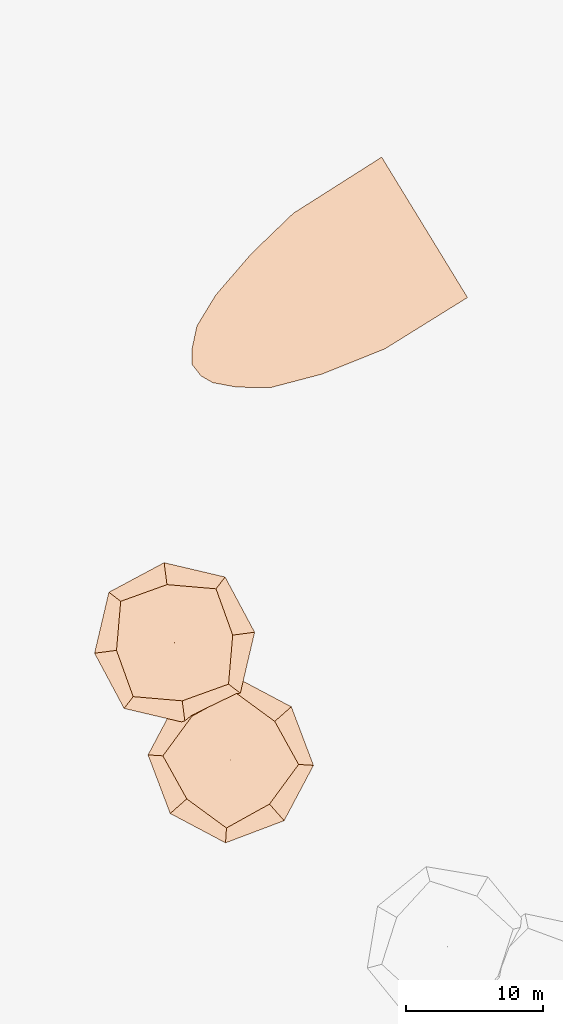
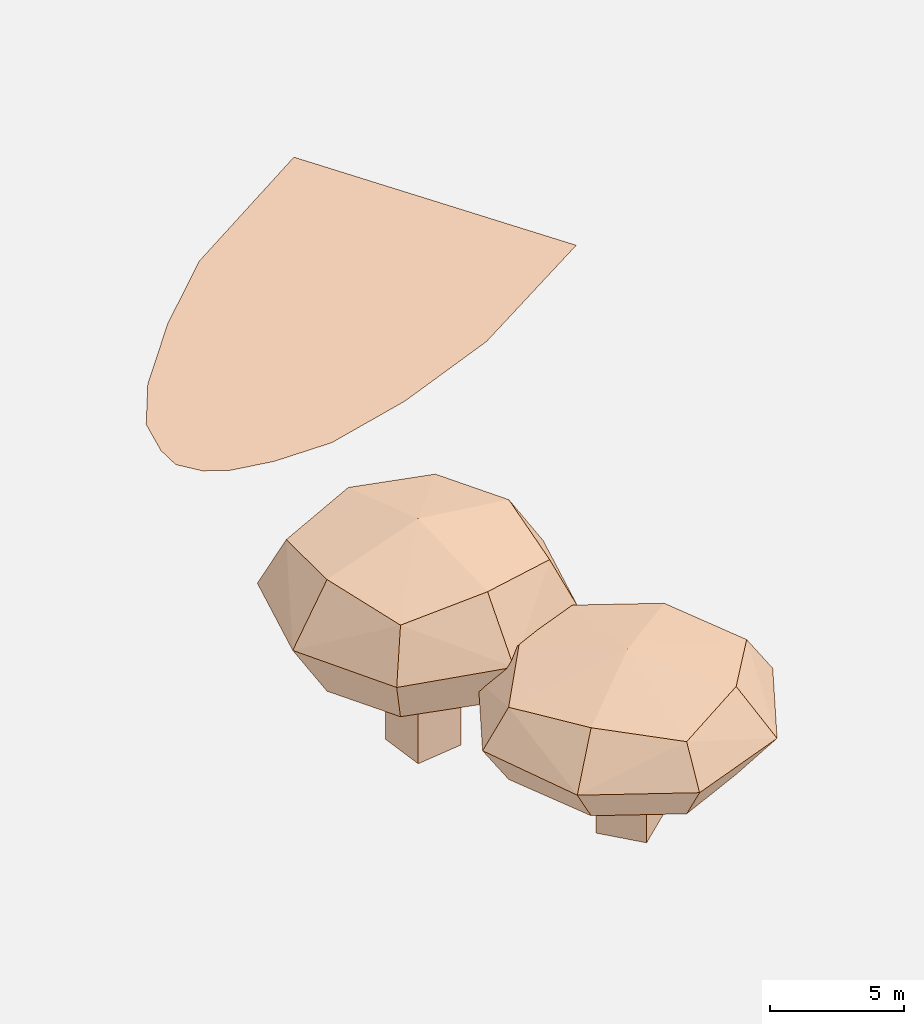
# Not in any storey, part 7 of 92: 3 geographic elements.
"""IFC4 model written with IfcOpenShell, lengths in metres."""

from ifc_helpers import new_model, si_unit, origin_with_axes, place, context, subcontext, project, spatial, triangles, material, element, save


model = new_model("IFC4")

# Units and contexts
model_context = context("Model", 3, precision=1e-05, world=origin_with_axes())
body_context = subcontext(model_context, "Body", "Model", "MODEL_VIEW")
ifc_project = project(units=[si_unit("VOLUMEUNIT", "CUBIC_METRE"), si_unit("LENGTHUNIT", "METRE"), si_unit("AREAUNIT", "SQUARE_METRE")], contexts=[model_context])

# Site
site_placement = place(None, origin_with_axes())
site = spatial("IfcSite", under=ifc_project, at=site_placement)

# Geographic elements
ifc_material_1 = material(Name="grass")
geographic_element_1_placement = place(site_placement, origin_with_axes())
element("IfcGeographicElement", 1, at=geographic_element_1_placement, inside=site, material=ifc_material_1, Name="cw_surface_grass", context=body_context, shape_type="Tessellation", body=[
    triangles([(428.3292698345774, -795.2040101195155, 0.0), (437.68484757364297, -795.2040101195155, 0.0), (435.03090837762966, -790.8601645183401, 0.0), (428.5964130531786, -794.9485099007724, 0.0), (421.5811732529401, -803.1426170163166, 0.0), (422.7426432110405, -807.277420437334, 0.0), (435.26319857055483, -804.815121837576, 0.0), (425.55337353890974, -797.8695821532289, 0.0), (421.2327379635523, -805.9533544667388, 0.0), (426.97036270922786, -807.6258592879982, 0.0), (435.03090837762966, -790.8543545206849, 0.0), (422.9517043846732, -800.8893819643757, 0.0), (421.2095089442598, -804.8848100825458, 0.0), (421.88315050374285, -806.7896062838224, 0.0), (424.5080676707464, -807.6026290816135, 0.0), (430.68704378297974, -806.6502309809752, 0.0), (441.27957154774055, -801.0752164929003, 0.0), (428.5964130531786, -794.942699012798, 0.0)], [[1, 2, 3], [3, 4, 1], [5, 6, 7], [7, 8, 5], [5, 9, 6], [6, 10, 7], [7, 11, 8], [8, 12, 5], [5, 13, 9], [9, 14, 6], [6, 15, 10], [10, 16, 7], [7, 17, 11], [11, 18, 8]], closed=False),
])
ifc_material_2 = material(Name="tree")
geographic_element_2_placement = place(site_placement, origin_with_axes())
element("IfcGeographicElement", 2, at=geographic_element_2_placement, inside=site, material=ifc_material_2, Name="cw_instances_tree_260", context=body_context, shape_type="Tessellation", body=[
    triangles([(421.0632924692762, -825.0554007047107, 5.950557368610615), (421.0632924692762, -825.0554007047107, 5.950557368610615), (421.0632924692762, -825.0554007047107, 5.950557368610615), (421.0632924692762, -825.0554007047107, 0.0), (421.0632924692762, -825.0554007047107, 0.0), (421.0632924692762, -825.0554007047107, 0.0), (421.3232781396344, -827.0384305711545, 5.950557368610615), (421.3232781396344, -827.0384305711545, 5.950557368610615), (421.3232781396344, -827.0384305711545, 5.950557368610615), (421.3232781396344, -827.0384305711545, 0.0), (421.3232781396344, -827.0384305711545, 0.0), (421.3232781396344, -827.0384305711545, 0.0), (419.0802626028323, -825.3153863750688, 5.950557368610615), (419.0802626028323, -825.3153863750688, 5.950557368610615), (419.0802626028323, -825.3153863750688, 5.950557368610615), (419.0802626028323, -825.3153863750688, 0.0), (419.0802626028323, -825.3153863750688, 0.0), (419.0802626028323, -825.3153863750688, 0.0), (419.3402482731905, -827.2984162415127, 5.950557368610615), (419.3402482731905, -827.2984162415127, 5.950557368610615), (419.3402482731905, -827.2984162415127, 5.950557368610615), (419.3402482731905, -827.2984162415127, 0.0), (419.3402482731905, -827.2984162415127, 0.0), (419.3402482731905, -827.2984162415127, 0.0), (422.97046032948157, -822.2839669872363, 8.863743321924314), (422.97046032948157, -822.2839669872363, 8.863743321924314), (422.97046032948157, -822.2839669872363, 8.863743321924314), (422.97046032948157, -822.2839669872363, 8.863743321924314), (422.97046032948157, -822.2839669872363, 8.863743321924314), (422.97046032948157, -822.2839669872363, 8.863743321924314), (422.9704605050486, -822.2839664801108, 4.698353330512501), (422.9704605050486, -822.2839664801108, 4.698353330512501), (422.9704605050486, -822.2839664801108, 4.698353330512501), (422.9704605050486, -822.2839664801108, 4.698353330512501), (422.9704605050486, -822.2839664801108, 4.698353330512501), (422.9704605050486, -822.2839664801108, 4.698353330512501), (423.88041019661085, -829.2245698327616, 8.863743321924314), (423.88041019661085, -829.2245698327616, 8.863743321924314), (423.88041019661085, -829.2245698327616, 8.863743321924314), (423.88041019661085, -829.2245698327616, 8.863743321924314), (423.88041019661085, -829.2245698327616, 8.863743321924314), (423.88041019661085, -829.2245698327616, 8.863743321924314), (423.88041019661085, -829.2245698327616, 4.698353330512501), (423.88041019661085, -829.2245698327616, 4.698353330512501), (423.88041019661085, -829.2245698327616, 4.698353330512501), (423.88041019661085, -829.2245698327616, 4.698353330512501), (423.88041019661085, -829.2245698327616, 4.698353330512501), (423.88041019661085, -829.2245698327616, 4.698353330512501), (416.02985643850707, -823.193916265268, 8.863743321924314), (416.02985643850707, -823.193916265268, 8.863743321924314), (416.02985643850707, -823.193916265268, 8.863743321924314), (416.02985643850707, -823.193916265268, 8.863743321924314), (416.02985643850707, -823.193916265268, 8.863743321924314), (416.02985643850707, -823.193916265268, 8.863743321924314), (416.0298569144343, -823.1939162028714, 4.698353330512501), (416.0298569144343, -823.1939162028714, 4.698353330512501), (416.0298569144343, -823.1939162028714, 4.698353330512501), (416.0298569144343, -823.1939162028714, 4.698353330512501), (416.0298569144343, -823.1939162028714, 4.698353330512501), (416.0298569144343, -823.1939162028714, 4.698353330512501), (416.9398061612676, -830.1345198558823, 8.863743321924314), (416.9398061612676, -830.1345198558823, 8.863743321924314), (416.9398061612676, -830.1345198558823, 8.863743321924314), (416.9398061612676, -830.1345198558823, 8.863743321924314), (416.9398061612676, -830.1345198558823, 8.863743321924314), (416.9398061612676, -830.1345198558823, 8.863743321924314), (416.9398061300693, -830.1345196179187, 4.698353330512501), (416.9398061300693, -830.1345196179187, 4.698353330512501), (416.9398061300693, -830.1345196179187, 4.698353330512501), (416.9398061300693, -830.1345196179187, 4.698353330512501), (416.9398061300693, -830.1345196179187, 4.698353330512501), (416.9398061300693, -830.1345196179187, 4.698353330512501), (415.72436421525055, -826.7639193198099, 4.241960964900109), (415.72436421525055, -826.7639193198099, 4.241960964900109), (415.72436421525055, -826.7639193198099, 4.241960964900109), (415.72436421525055, -826.7639193198099, 4.241960964900109), (419.40045729201717, -821.9784745096014, 4.241960964900109), (419.40045729201717, -821.9784745096014, 4.241960964900109), (419.40045729201717, -821.9784745096014, 4.241960964900109), (419.40045729201717, -821.9784745096014, 4.241960964900109), (423.63122591115956, -821.4237984383071, 6.781048683251871), (423.63122591115956, -821.4237984383071, 6.781048683251871), (423.63122591115956, -821.4237984383071, 6.781048683251871), (423.63122591115956, -821.4237984383071, 6.781048683251871), (416.2790402891446, -830.9946879587826, 6.781048683251871), (416.2790402891446, -830.9946879587826, 6.781048683251871), (416.2790402891446, -830.9946879587826, 6.781048683251871), (416.2790402891446, -830.9946879587826, 6.781048683251871), (424.74057858995616, -829.8853361509134, 6.781048683251871), (424.74057858995616, -829.8853361509134, 6.781048683251871), (424.74057858995616, -829.8853361509134, 6.781048683251871), (424.74057858995616, -829.8853361509134, 6.781048683251871), (415.1696886133838, -822.5331505886952, 6.781048683251871), (415.1696886133838, -822.5331505886952, 6.781048683251871), (415.1696886133838, -822.5331505886952, 6.781048683251871), (415.1696886133838, -822.5331505886952, 6.781048683251871), (420.5098095048017, -830.4400122833043, 9.320135330503241), (420.5098095048017, -830.4400122833043, 9.320135330503241), (420.5098095048017, -830.4400122833043, 9.320135330503241), (420.5098095048017, -830.4400122833043, 9.320135330503241), (424.18590244196616, -825.6545669467772, 9.320136728884307), (424.18590244196616, -825.6545669467772, 9.320136728884307), (424.18590244196616, -825.6545669467772, 9.320136728884307), (424.18590244196616, -825.6545669467772, 9.320136728884307), (420.5098093941293, -830.4400118237919, 4.241960964900109), (420.5098093941293, -830.4400118237919, 4.241960964900109), (420.5098093941293, -830.4400118237919, 4.241960964900109), (420.5098093941293, -830.4400118237919, 4.241960964900109), (415.7243642100508, -826.7639192801493, 9.320135330503241), (415.7243642100508, -826.7639192801493, 9.320135330503241), (415.7243642100508, -826.7639192801493, 9.320135330503241), (415.7243642100508, -826.7639192801493, 9.320135330503241), (419.4004573217626, -821.9784745057016, 9.320136728884307), (419.4004573217626, -821.9784745057016, 9.320136728884307), (419.4004573217626, -821.9784745057016, 9.320136728884307), (419.4004573217626, -821.9784745057016, 9.320136728884307), (424.1859019837537, -825.6545670673647, 4.241960964900109), (424.1859019837537, -825.6545670673647, 4.241960964900109), (424.1859019837537, -825.6545670673647, 4.241960964900109), (424.1859019837537, -825.6545670673647, 4.241960964900109), (419.955133268391, -826.2092430201615, 10.27791981565272), (419.955133268391, -826.2092430201615, 10.27791981565272), (419.955133268391, -826.2092430201615, 10.27791981565272), (419.955133268391, -826.2092430201615, 10.27791981565272), (419.955133268391, -826.2092430201615, 10.27791981565272), (419.955133268391, -826.2092430201615, 10.27791981565272), (419.955133268391, -826.2092430201615, 10.27791981565272), (419.955133268391, -826.2092430201615, 10.27791981565272), (420.7190417657378, -832.0359226343951, 6.781048683251871), (420.7190417657378, -832.0359226343951, 6.781048683251871), (420.7190417657378, -832.0359226343951, 6.781048683251871), (420.7190417657378, -832.0359226343951, 6.781048683251871), (420.7190417657378, -832.0359226343951, 6.781048683251871), (420.7190417657378, -832.0359226343951, 6.781048683251871), (420.7190417657378, -832.0359226343951, 6.781048683251871), (420.7190417657378, -832.0359226343951, 6.781048683251871), (414.1284538602599, -826.9731515510006, 6.781048683251871), (414.1284538602599, -826.9731515510006, 6.781048683251871), (414.1284538602599, -826.9731515510006, 6.781048683251871), (414.1284538602599, -826.9731515510006, 6.781048683251871), (414.1284538602599, -826.9731515510006, 6.781048683251871), (414.1284538602599, -826.9731515510006, 6.781048683251871), (414.1284538602599, -826.9731515510006, 6.781048683251871), (414.1284538602599, -826.9731515510006, 6.781048683251871), (419.9551334072031, -826.2092430019625, 3.28417823516516), (419.9551334072031, -826.2092430019625, 3.28417823516516), (419.9551334072031, -826.2092430019625, 3.28417823516516), (419.9551334072031, -826.2092430019625, 3.28417823516516), (419.9551334072031, -826.2092430019625, 3.28417823516516), (419.9551334072031, -826.2092430019625, 3.28417823516516), (419.9551334072031, -826.2092430019625, 3.28417823516516), (419.9551334072031, -826.2092430019625, 3.28417823516516), (425.7818123179454, -825.4453346775317, 6.781048683251871), (425.7818123179454, -825.4453346775317, 6.781048683251871), (425.7818123179454, -825.4453346775317, 6.781048683251871), (425.7818123179454, -825.4453346775317, 6.781048683251871), (425.7818123179454, -825.4453346775317, 6.781048683251871), (425.7818123179454, -825.4453346775317, 6.781048683251871), (425.7818123179454, -825.4453346775317, 6.781048683251871), (425.7818123179454, -825.4453346775317, 6.781048683251871), (419.1912249191087, -820.3825636890831, 6.781048683251871), (419.1912249191087, -820.3825636890831, 6.781048683251871), (419.1912249191087, -820.3825636890831, 6.781048683251871), (419.1912249191087, -820.3825636890831, 6.781048683251871), (419.1912249191087, -820.3825636890831, 6.781048683251871), (419.1912249191087, -820.3825636890831, 6.781048683251871), (419.1912249191087, -820.3825636890831, 6.781048683251871), (419.1912249191087, -820.3825636890831, 6.781048683251871)], [[15, 8, 2], [7, 24, 11], [19, 16, 22], [4, 23, 17], [3, 12, 6], [14, 5, 18], [26, 127, 101], [54, 123, 114], [124, 66, 98], [128, 38, 102], [45, 133, 108], [40, 135, 89], [130, 63, 88], [131, 70, 105], [68, 141, 73], [61, 140, 86], [137, 49, 93], [142, 56, 74], [59, 145, 75], [31, 149, 79], [150, 43, 107], [146, 71, 76], [35, 154, 120], [30, 157, 83], [158, 42, 91], [153, 47, 119], [58, 164, 77], [51, 162, 96], [167, 28, 81], [165, 33, 80], [15, 21, 8], [7, 20, 24], [19, 13, 16], [4, 10, 23], [3, 9, 12], [14, 1, 5], [25, 115, 126], [53, 111, 121], [122, 112, 65], [125, 99, 37], [46, 90, 136], [39, 100, 134], [132, 97, 64], [129, 87, 69], [67, 85, 138], [62, 110, 144], [143, 109, 50], [139, 94, 55], [60, 78, 147], [32, 117, 151], [152, 118, 44], [148, 106, 72], [36, 84, 160], [29, 104, 156], [155, 103, 41], [159, 92, 48], [57, 95, 161], [52, 113, 163], [166, 116, 27], [168, 82, 34]], closed=True),
])
geographic_element_3_placement = place(site_placement, origin_with_axes())
element("IfcGeographicElement", 3, at=geographic_element_3_placement, inside=site, material=ifc_material_2, Name="cw_instances_tree_261", context=body_context, shape_type="Tessellation", body=[
    triangles([(424.31929825502226, -833.181753324099, 4.690448628812901), (424.31929825502226, -833.181753324099, 4.690448628812901), (424.31929825502226, -833.181753324099, 4.690448628812901), (424.31929825502226, -833.181753324099, 0.0), (424.31929825502226, -833.181753324099, 0.0), (424.31929825502226, -833.181753324099, 0.0), (425.6415102645461, -834.6823383439732, 4.690448628812901), (425.6415102645461, -834.6823383439732, 4.690448628812901), (425.6415102645461, -834.6823383439732, 4.690448628812901), (425.6415102645461, -834.6823383439732, 0.0), (425.6415102645461, -834.6823383439732, 0.0), (425.6415102645461, -834.6823383439732, 0.0), (422.81871323514804, -834.5039653336229, 4.690448628812901), (422.81871323514804, -834.5039653336229, 4.690448628812901), (422.81871323514804, -834.5039653336229, 4.690448628812901), (422.81871323514804, -834.5039653336229, 0.0), (422.81871323514804, -834.5039653336229, 0.0), (422.81871323514804, -834.5039653336229, 0.0), (424.1409252446719, -836.004550353497, 4.690448628812901), (424.1409252446719, -836.004550353497, 4.690448628812901), (424.1409252446719, -836.004550353497, 4.690448628812901), (424.1409252446719, -836.004550353497, 0.0), (424.1409252446719, -836.004550353497, 0.0), (424.1409252446719, -836.004550353497, 0.0), (424.3556308703463, -829.8177060535605, 6.9867291641920035), (424.3556308703463, -829.8177060535605, 6.9867291641920035), (424.3556308703463, -829.8177060535605, 6.9867291641920035), (424.3556308703463, -829.8177060535605, 6.9867291641920035), (424.3556308703463, -829.8177060535605, 6.9867291641920035), (424.3556308703463, -829.8177060535605, 6.9867291641920035), (424.3556307330856, -829.8177055347546, 3.7034152553555426), (424.3556307330856, -829.8177055347546, 3.7034152553555426), (424.3556307330856, -829.8177055347546, 3.7034152553555426), (424.3556307330856, -829.8177055347546, 3.7034152553555426), (424.3556307330856, -829.8177055347546, 3.7034152553555426), (424.3556307330856, -829.8177055347546, 3.7034152553555426), (428.9833719797029, -835.0697522114664, 6.9867291641920035), (428.9833719797029, -835.0697522114664, 6.9867291641920035), (428.9833719797029, -835.0697522114664, 6.9867291641920035), (428.9833719797029, -835.0697522114664, 6.9867291641920035), (428.9833719797029, -835.0697522114664, 6.9867291641920035), (428.9833719797029, -835.0697522114664, 6.9867291641920035), (428.9833719797029, -835.0697522114664, 3.7034152553555426), (428.9833719797029, -835.0697522114664, 3.7034152553555426), (428.9833719797029, -835.0697522114664, 3.7034152553555426), (428.9833719797029, -835.0697522114664, 3.7034152553555426), (428.9833719797029, -835.0697522114664, 3.7034152553555426), (428.9833719797029, -835.0697522114664, 3.7034152553555426), (419.1035835161633, -834.4454472573683, 6.9867291641920035), (419.1035835161633, -834.4454472573683, 6.9867291641920035), (419.1035835161633, -834.4454472573683, 6.9867291641920035), (419.1035835161633, -834.4454472573683, 6.9867291641920035), (419.1035835161633, -834.4454472573683, 6.9867291641920035), (419.1035835161633, -834.4454472573683, 6.9867291641920035), (419.10358387630373, -834.4454469400374, 3.7034152553555426), (419.10358387630373, -834.4454469400374, 3.7034152553555426), (419.10358387630373, -834.4454469400374, 3.7034152553555426), (419.10358387630373, -834.4454469400374, 3.7034152553555426), (419.10358387630373, -834.4454469400374, 3.7034152553555426), (419.10358387630373, -834.4454469400374, 3.7034152553555426), (423.73132492144606, -839.6974941141502, 6.9867291641920035), (423.73132492144606, -839.6974941141502, 6.9867291641920035), (423.73132492144606, -839.6974941141502, 6.9867291641920035), (423.73132492144606, -839.6974941141502, 6.9867291641920035), (423.73132492144606, -839.6974941141502, 6.9867291641920035), (423.73132492144606, -839.6974941141502, 6.9867291641920035), (423.7313247627806, -839.69749393408, 3.7034152553555426), (423.7313247627806, -839.69749393408, 3.7034152553555426), (423.7313247627806, -839.69749393408, 3.7034152553555426), (423.7313247627806, -839.69749393408, 3.7034152553555426), (423.7313247627806, -839.69749393408, 3.7034152553555426), (423.7313247627806, -839.69749393408, 3.7034152553555426), (420.84199869093567, -837.5785224221274, 3.3436699722028242), (420.84199869093567, -837.5785224221274, 3.3436699722028242), (420.84199869093567, -837.5785224221274, 3.3436699722028242), (420.84199869093567, -837.5785224221274, 3.3436699722028242), (421.2225555778253, -831.5561210077044, 3.3436699722028242), (421.2225555778253, -831.5561210077044, 3.3436699722028242), (421.2225555778253, -831.5561210077044, 3.3436699722028242), (421.2225555778253, -831.5561210077044, 3.3436699722028242), (424.42403434517433, -828.7351987551424, 5.345072491200708), (424.42403434517433, -828.7351987551424, 5.345072491200708), (424.42403434517433, -828.7351987551424, 5.345072491200708), (424.42403434517433, -828.7351987551424, 5.345072491200708), (423.66292095671986, -840.7800012044823, 5.345072491200708), (423.66292095671986, -840.7800012044823, 5.345072491200708), (423.66292095671986, -840.7800012044823, 5.345072491200708), (423.66292095671986, -840.7800012044823, 5.345072491200708), (430.0658795599332, -835.1381563842785, 5.345072491200708), (430.0658795599332, -835.1381563842785, 5.345072491200708), (430.0658795599332, -835.1381563842785, 5.345072491200708), (430.0658795599332, -835.1381563842785, 5.345072491200708), (418.0210767654587, -834.3770432999329, 5.345072491200708), (418.0210767654587, -834.3770432999329, 5.345072491200708), (418.0210767654587, -834.3770432999329, 5.345072491200708), (418.0210767654587, -834.3770432999329, 5.345072491200708), (426.8644004399467, -837.9590789475604, 7.346474165917787), (426.8644004399467, -837.9590789475604, 7.346474165917787), (426.8644004399467, -837.9590789475604, 7.346474165917787), (426.8644004399467, -837.9590789475604, 7.346474165917787), (427.2449569173186, -831.9366771742569, 7.346475268173281), (427.2449569173186, -831.9366771742569, 7.346475268173281), (427.2449569173186, -831.9366771742569, 7.346475268173281), (427.2449569173186, -831.9366771742569, 7.346475268173281), (426.86440009171224, -837.9590786279783, 3.3436699722028242), (426.86440009171224, -837.9590786279783, 3.3436699722028242), (426.86440009171224, -837.9590786279783, 3.3436699722028242), (426.86440009171224, -837.9590786279783, 3.3436699722028242), (420.8419986644914, -837.5785223921157, 7.346474165917787), (420.8419986644914, -837.5785223921157, 7.346474165917787), (420.8419986644914, -837.5785223921157, 7.346474165917787), (420.8419986644914, -837.5785223921157, 7.346474165917787), (421.2225556003341, -831.5561209878713, 7.346475268173281), (421.2225556003341, -831.5561209878713, 7.346475268173281), (421.2225556003341, -831.5561209878713, 7.346475268173281), (421.2225556003341, -831.5561209878713, 7.346475268173281), (427.24495660434746, -831.9366775299943, 3.3436699722028242), (427.24495660434746, -831.9366775299943, 3.3436699722028242), (427.24495660434746, -831.9366775299943, 3.3436699722028242), (427.24495660434746, -831.9366775299943, 3.3436699722028242), (424.0434776910312, -834.7575997379068, 8.101435196755906), (424.0434776910312, -834.7575997379068, 8.101435196755906), (424.0434776910312, -834.7575997379068, 8.101435196755906), (424.0434776910312, -834.7575997379068, 8.101435196755906), (424.0434776910312, -834.7575997379068, 8.101435196755906), (424.0434776910312, -834.7575997379068, 8.101435196755906), (424.0434776910312, -834.7575997379068, 8.101435196755906), (424.0434776910312, -834.7575997379068, 8.101435196755906), (427.92849527182113, -839.1667254920897, 5.345072491200708), (427.92849527182113, -839.1667254920897, 5.345072491200708), (427.92849527182113, -839.1667254920897, 5.345072491200708), (427.92849527182113, -839.1667254920897, 5.345072491200708), (427.92849527182113, -839.1667254920897, 5.345072491200708), (427.92849527182113, -839.1667254920897, 5.345072491200708), (427.92849527182113, -839.1667254920897, 5.345072491200708), (427.92849527182113, -839.1667254920897, 5.345072491200708), (419.63435212657333, -838.6426172314931, 5.345072491200708), (419.63435212657333, -838.6426172314931, 5.345072491200708), (419.63435212657333, -838.6426172314931, 5.345072491200708), (419.63435212657333, -838.6426172314931, 5.345072491200708), (419.63435212657333, -838.6426172314931, 5.345072491200708), (419.63435212657333, -838.6426172314931, 5.345072491200708), (419.63435212657333, -838.6426172314931, 5.345072491200708), (419.63435212657333, -838.6426172314931, 5.345072491200708), (424.0434777960722, -834.757599645352, 2.588710325047133), (424.0434777960722, -834.757599645352, 2.588710325047133), (424.0434777960722, -834.757599645352, 2.588710325047133), (424.0434777960722, -834.757599645352, 2.588710325047133), (424.0434777960722, -834.757599645352, 2.588710325047133), (424.0434777960722, -834.757599645352, 2.588710325047133), (424.0434777960722, -834.757599645352, 2.588710325047133), (424.0434777960722, -834.757599645352, 2.588710325047133), (428.45260306293284, -830.8725826005818, 5.345072491200708), (428.45260306293284, -830.8725826005818, 5.345072491200708), (428.45260306293284, -830.8725826005818, 5.345072491200708), (428.45260306293284, -830.8725826005818, 5.345072491200708), (428.45260306293284, -830.8725826005818, 5.345072491200708), (428.45260306293284, -830.8725826005818, 5.345072491200708), (428.45260306293284, -830.8725826005818, 5.345072491200708), (428.45260306293284, -830.8725826005818, 5.345072491200708), (420.1584603911053, -830.3484741360902, 5.345072491200708), (420.1584603911053, -830.3484741360902, 5.345072491200708), (420.1584603911053, -830.3484741360902, 5.345072491200708), (420.1584603911053, -830.3484741360902, 5.345072491200708), (420.1584603911053, -830.3484741360902, 5.345072491200708), (420.1584603911053, -830.3484741360902, 5.345072491200708), (420.1584603911053, -830.3484741360902, 5.345072491200708), (420.1584603911053, -830.3484741360902, 5.345072491200708)], [[15, 8, 2], [7, 24, 11], [19, 16, 22], [4, 23, 17], [3, 12, 6], [14, 5, 18], [26, 127, 101], [54, 123, 114], [124, 66, 98], [128, 38, 102], [45, 133, 108], [40, 135, 89], [130, 63, 88], [131, 70, 105], [68, 141, 73], [61, 140, 86], [137, 49, 93], [142, 56, 74], [59, 145, 75], [31, 149, 79], [150, 43, 107], [146, 71, 76], [35, 154, 120], [30, 157, 83], [158, 42, 91], [153, 47, 119], [58, 164, 77], [51, 162, 96], [167, 28, 81], [165, 33, 80], [15, 21, 8], [7, 20, 24], [19, 13, 16], [4, 10, 23], [3, 9, 12], [14, 1, 5], [25, 115, 126], [53, 111, 121], [122, 112, 65], [125, 99, 37], [46, 90, 136], [39, 100, 134], [132, 97, 64], [129, 87, 69], [67, 85, 138], [62, 110, 144], [143, 109, 50], [139, 94, 55], [60, 78, 147], [32, 117, 151], [152, 118, 44], [148, 106, 72], [36, 84, 160], [29, 104, 156], [155, 103, 41], [159, 92, 48], [57, 95, 161], [52, 113, 163], [166, 116, 27], [168, 82, 34]], closed=True),
])

save(model, "model.ifc")
